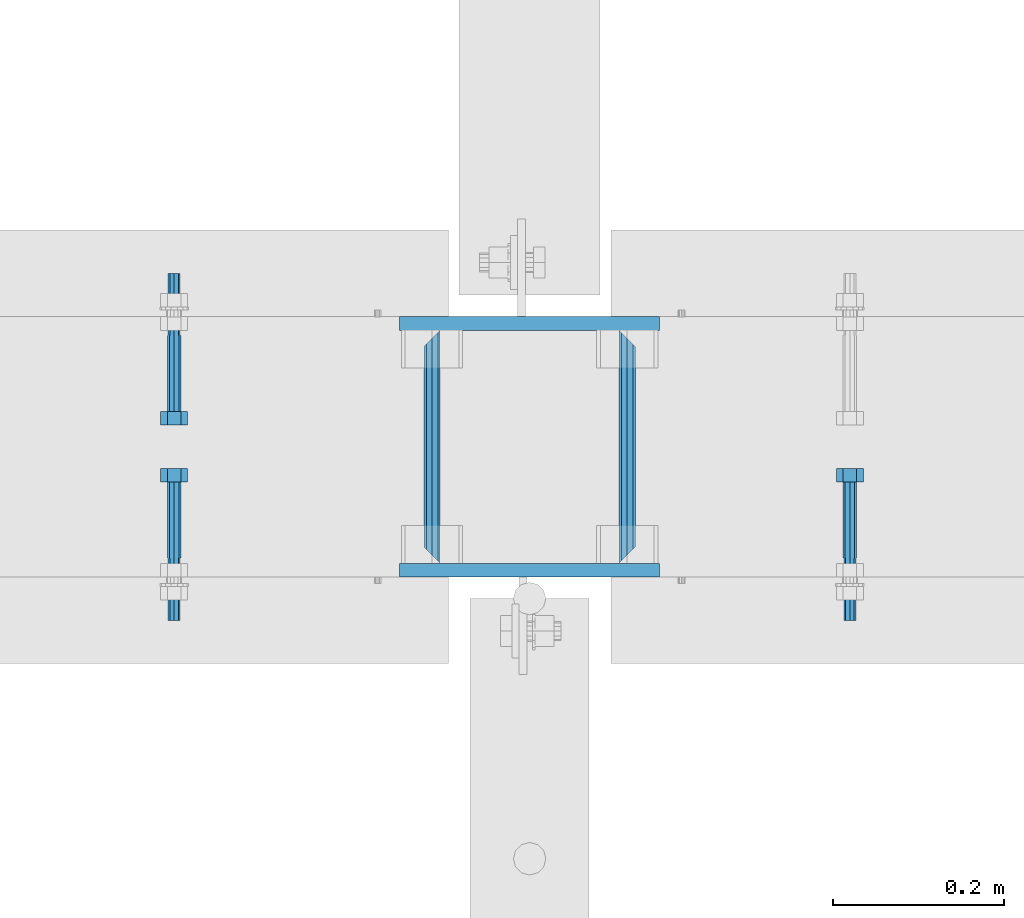
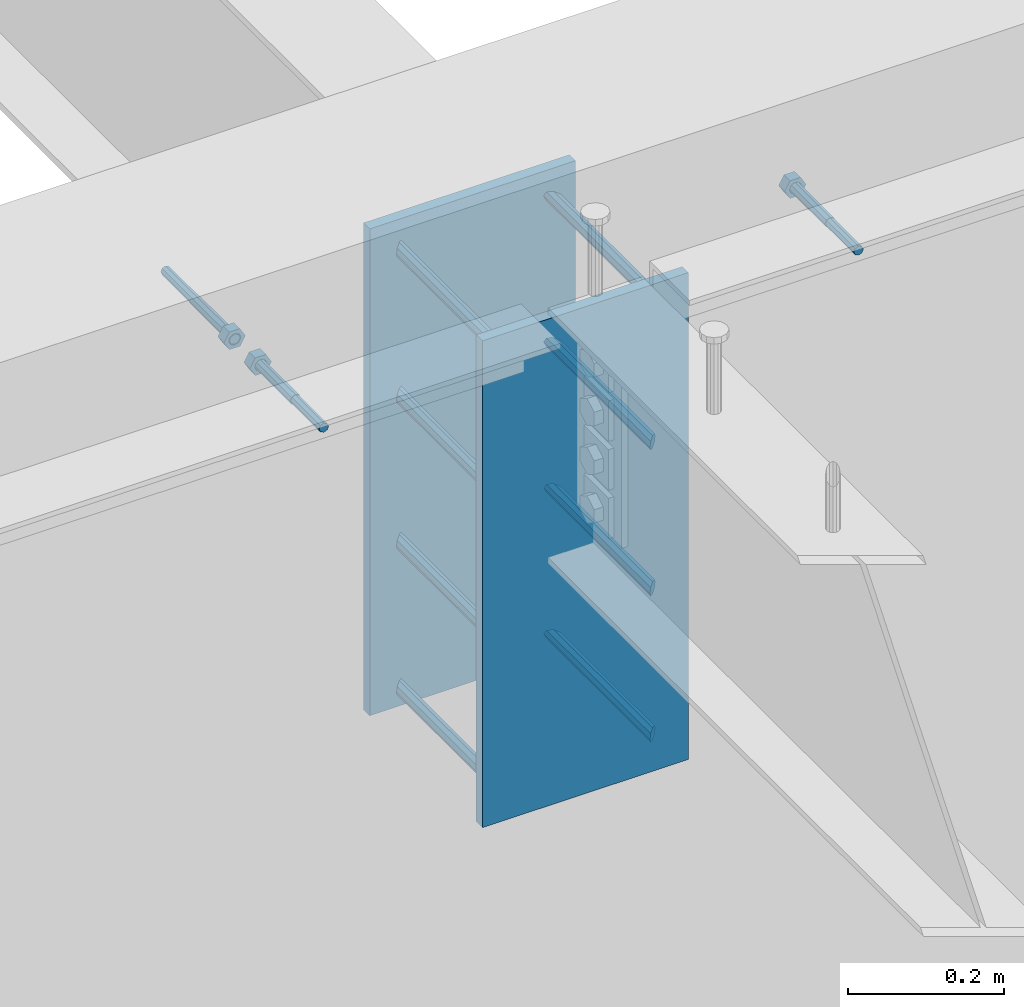
# One storey, part 428 of 975: 13 beams.
"""IFC2X3 building model written with IfcOpenShell, lengths in millimetres."""

from ifc_helpers import new_model, si_unit, frame, origin_with_axes, place, context, subcontext, project, spatial, faceted_brep, material, type_object, element, save


model = new_model("IFC2X3")

# Units and contexts
model_context = context("Model", 3, precision=1e-05, world=origin_with_axes())
body_context = subcontext(model_context, "Body", "Model", "MODEL_VIEW")
ifc_project = project(units=[si_unit("LENGTHUNIT", "METRE", prefix="MILLI"), si_unit("AREAUNIT", "SQUARE_METRE"), si_unit("VOLUMEUNIT", "CUBIC_METRE"), si_unit("MASSUNIT", "GRAM", prefix="KILO"), si_unit("TIMEUNIT", "SECOND"), si_unit("PLANEANGLEUNIT", "RADIAN"), si_unit("SOLIDANGLEUNIT", "STERADIAN"), si_unit("THERMODYNAMICTEMPERATUREUNIT", "DEGREE_CELSIUS"), si_unit("LUMINOUSINTENSITYUNIT", "LUMEN")], contexts=[model_context])

# Site, building, storey
site_placement = place(None, origin_with_axes())
site = spatial("IfcSite", under=ifc_project, at=site_placement, CompositionType="ELEMENT")
building_placement = place(site_placement, origin_with_axes())
building = spatial("IfcBuilding", under=site, at=building_placement, Name="Undefined", CompositionType="ELEMENT")
storey_placement = place(building_placement, origin_with_axes())
storey = spatial("IfcBuildingStorey", under=building, at=storey_placement, Name="Undefined", CompositionType="ELEMENT", Elevation=0.0)

# Beams
ifc_material_1 = material(Name="STEEL/F1554-36")
beam_type_1 = type_object("IfcBeamType", PredefinedType="NOTDEFINED")
beam_1_placement = place(storey_placement, frame((3874.0292047886, 20726.3999996637, 3886.2), z_axis=(0.0, 0.0, 1.0), x_axis=(0.0, -1.0, 0.0)))
element("IfcBeam", 1, at=beam_1_placement, inside=storey, type_object=beam_type_1, material=ifc_material_1, Name="HEADED_ANCHOR_BOLT", context=body_context, shape_type="Brep", body=[
    faceted_brep([(88.9000000184824, 7.94000001861696, -13.7499999799138), (88.8999999527368, 15.8800000758411, 2.00943759409711e-08), (104.774999952569, 15.8800001213949, 6.97191353538074e-08), (104.775000018315, 7.94000006417082, -13.7499999302891), (88.900000064019, -7.94000009583215, -13.7499999799147), (104.775000063852, -7.9400000502792, -13.74999993029), (88.9000000438027, -15.880000153059, 2.00925569515675e-08), (104.775000043643, -15.8800001075042, 6.9716406869702e-08), (88.8999999780608, -7.94000009583488, 13.7500000200998), (104.774999977893, -7.94000005028101, 13.7500000697237), (88.8999999325279, 7.94000001861514, 13.7500000201007), (104.774999932361, 7.940000064169, 13.7500000697246), (88.9000000119959, 3.78780480527439, -7.86545778426807), (88.8999999957159, 6.82538844544797, -5.4430656647246), (88.8999999799416, 8.51112018845743, -1.94260763148395), (88.8999999677944, 8.51112018845652, 1.94260767167179), (88.8999999616899, 6.82538844544615, 5.44306570491244), (88.8999999628249, 3.78780480527257, 7.86545782445592), (88.8999999709849, -3.86089595849626e-08, 8.72999956233434), (88.8999999845473, -3.7878048824914, 7.8654578244541), (88.9000000008309, -6.82538852266407, 5.44306570491153), (88.9000000166052, -8.51112026567444, 1.94260767166998), (88.9000000287488, -8.51112026567353, -1.94260763148577), (88.9000000348606, -6.82538852266407, -5.44306566472642), (88.9000000337182, -3.78780488248958, -7.86545778426898), (88.9000000255583, -3.86080500902608e-08, -8.72999952214832), (104.775000025395, 6.94581103743985e-09, -8.72999947252447), (104.775000011829, 3.78780485082825, -7.86545773464422), (104.774999995549, 6.82538849100092, -5.44306561510075), (104.774999979774, 8.51112023401038, -1.9426075818601), (104.774999967627, 8.51112023401038, 1.94260772129564), (104.774999961523, 6.82538849100092, 5.44306575453629), (104.774999962658, 3.78780485082643, 7.86545787407977), (104.774999970818, 6.94399204803631e-09, 8.7299996119591), (104.77499998438, -3.78780483693754, 7.86545787407886), (104.775000000664, -6.82538847711112, 5.44306575453538), (104.775000016438, -8.51112022012057, 1.94260772129473), (104.775000028581, -8.51112022012057, -1.94260758186101), (104.775000034693, -6.82538847711021, -5.44306561510166), (104.775000033551, -3.78780483693663, -7.86545773464422), (-2.99107341561466e-07, -5.61266007567065, 5.61266007566792), (-4.22995071858168e-07, -7.93750000000728, 0.0), (104.774999998088, -7.93749999999, -4.45652403868735e-11), (104.774999998088, -5.61266007565791, 5.61266007562426), (-1.09139364212751e-11, 1.81898940354586e-12, 7.9375), (104.774999998095, 1.18234311230481e-11, 7.93749999995816), (2.99089151667431e-07, 5.61266007567428, 5.61266007566792), (104.774999998102, 5.61266007568065, 5.61266007562517), (4.22980519942939e-07, 7.93750000001091, 0.0), (104.77499999811, 7.93750000001364, -4.36557456851006e-11), (2.99089151667431e-07, 5.61266007567428, -5.61266007566792), (104.774999998102, 5.61266007568156, -5.61266007571339), (-1.09139364212751e-11, 1.81898940354586e-12, -7.9375), (104.774999998099, 1.2732925824821e-11, -7.93750000004547), (-73.0249999592124, 5.05157065939329, -5.0515715445581), (-73.0249999269472, -1.85405951924622e-07, -7.14400069976364), (-73.0249999328516, -5.0515710302052, -5.05157154455992), (-73.0249999734697, -7.14400018541073, -6.9975976657588e-07), (-73.0250000250016, -5.05157103020611, 5.05157014504039), (-73.0250000572705, -1.85406861419324e-07, 7.1439993002441), (-73.0250000513661, 5.05157065939238, 5.05157014503948), (-73.025000010748, 7.14399981459792, -6.99758857081179e-07), (0.00625003290042514, 5.05157085007795, -5.05157087849238), (0.00625006516929716, 5.27870724909008e-09, -7.1440000336961), (0.00625005926485755, -5.05157083952145, -5.05157087849329), (0.00625001864682417, -7.14399999472516, -3.36940502165817e-08), (0.00624996711121639, -5.05157083952145, 5.05157081110519), (0.00624993484598235, 5.2777977543883e-09, 7.14399996631164), (0.00624994074678398, 5.05157085007704, 5.05157081110701), (0.00624998136845534, 7.14400000528167, -3.36922312271781e-08), (-2.99107341561466e-07, -5.61266007567065, -5.61266007566792), (104.774999998092, -5.612660075657, -5.6126600757143)], [[[0, 1, 2, 3]], [[4, 0, 3, 5]], [[6, 4, 5, 7]], [[8, 6, 7, 9]], [[10, 8, 9, 11]], [[0, 4, 6, 8, 10, 1], [12, 13, 14, 15, 16, 17, 18, 19, 20, 21, 22, 23, 24, 25]], [[12, 25, 26, 27]], [[13, 12, 27, 28]], [[14, 13, 28, 29]], [[15, 14, 29, 30]], [[16, 15, 30, 31]], [[17, 16, 31, 32]], [[18, 17, 32, 33]], [[19, 18, 33, 34]], [[20, 19, 34, 35]], [[21, 20, 35, 36]], [[22, 21, 36, 37]], [[23, 22, 37, 38]], [[24, 23, 38, 39]], [[25, 24, 39, 26]], [[9, 7, 5, 3, 2, 11], [38, 37, 36, 35, 34, 33, 32, 31, 30, 29, 28, 27, 26, 39]], [[1, 10, 11, 2]], [[40, 41, 42, 43]], [[44, 40, 43, 45]], [[46, 44, 45, 47]], [[48, 46, 47, 49]], [[50, 48, 49, 51]], [[52, 50, 51, 53]], [[54, 55, 56, 57, 58, 59, 60, 61]], [[55, 54, 62, 63]], [[56, 55, 63, 64]], [[57, 56, 64, 65]], [[58, 57, 65, 66]], [[59, 58, 66, 67]], [[60, 59, 67, 68]], [[61, 60, 68, 69]], [[54, 61, 69, 62]], [[40, 44, 46, 48, 50, 52, 70, 41], [68, 67, 66, 65, 64, 63, 62, 69]], [[41, 70, 71, 42]], [[53, 51, 49, 47, 45, 43, 42, 71]], [[70, 52, 53, 71]]]),
])
beam_2_placement = place(storey_placement, frame((4665.66261822082, 20466.05, 3886.2), z_axis=(0.0, 0.0, 1.0), x_axis=(0.0, 1.0, 0.0)))
element("IfcBeam", 2, at=beam_2_placement, inside=storey, type_object=beam_type_1, material=ifc_material_1, Name="HEADED_ANCHOR_BOLT", context=body_context, shape_type="Brep", body=[
    faceted_brep([(88.9000000184824, 7.94000001861696, -13.7499999799138), (88.8999999527368, 15.8800000758411, 2.00943759409711e-08), (104.774999952569, 15.8800001213949, 6.97191353538074e-08), (104.775000018315, 7.94000006417082, -13.7499999302891), (88.900000064019, -7.94000009583215, -13.7499999799147), (104.775000063852, -7.9400000502792, -13.74999993029), (88.9000000438027, -15.880000153059, 2.00925569515675e-08), (104.775000043643, -15.8800001075042, 6.9716406869702e-08), (88.8999999780608, -7.94000009583488, 13.7500000200998), (104.774999977893, -7.94000005028101, 13.7500000697237), (88.8999999325279, 7.94000001861514, 13.7500000201007), (104.774999932361, 7.940000064169, 13.7500000697246), (88.9000000119959, 3.78780480527439, -7.86545778426807), (88.8999999957159, 6.82538844544797, -5.4430656647246), (88.8999999799416, 8.51112018845743, -1.94260763148395), (88.8999999677944, 8.51112018845652, 1.94260767167179), (88.8999999616899, 6.82538844544615, 5.44306570491244), (88.8999999628249, 3.78780480527257, 7.86545782445592), (88.8999999709849, -3.86089595849626e-08, 8.72999956233434), (88.8999999845473, -3.7878048824914, 7.8654578244541), (88.9000000008309, -6.82538852266407, 5.44306570491153), (88.9000000166052, -8.51112026567444, 1.94260767166998), (88.9000000287488, -8.51112026567353, -1.94260763148577), (88.9000000348606, -6.82538852266407, -5.44306566472642), (88.9000000337182, -3.78780488248958, -7.86545778426898), (88.9000000255583, -3.86080500902608e-08, -8.72999952214832), (104.775000025395, 6.94581103743985e-09, -8.72999947252447), (104.775000011829, 3.78780485082825, -7.86545773464422), (104.774999995549, 6.82538849100092, -5.44306561510075), (104.774999979774, 8.51112023401038, -1.9426075818601), (104.774999967627, 8.51112023401038, 1.94260772129564), (104.774999961523, 6.82538849100092, 5.44306575453629), (104.774999962658, 3.78780485082643, 7.86545787407977), (104.774999970818, 6.94399204803631e-09, 8.7299996119591), (104.77499998438, -3.78780483693754, 7.86545787407886), (104.775000000664, -6.82538847711112, 5.44306575453538), (104.775000016438, -8.51112022012057, 1.94260772129473), (104.775000028581, -8.51112022012057, -1.94260758186101), (104.775000034693, -6.82538847711021, -5.44306561510166), (104.775000033551, -3.78780483693663, -7.86545773464422), (-2.99107341561466e-07, -5.61266007567065, 5.61266007566792), (-4.22995071858168e-07, -7.93750000000728, 0.0), (104.774999998088, -7.93749999999, -4.45652403868735e-11), (104.774999998088, -5.61266007565791, 5.61266007562426), (-1.09139364212751e-11, 1.81898940354586e-12, 7.9375), (104.774999998095, 1.18234311230481e-11, 7.93749999995816), (2.99089151667431e-07, 5.61266007567428, 5.61266007566792), (104.774999998102, 5.61266007568065, 5.61266007562517), (4.22980519942939e-07, 7.93750000001091, 0.0), (104.77499999811, 7.93750000001364, -4.36557456851006e-11), (2.99089151667431e-07, 5.61266007567428, -5.61266007566792), (104.774999998102, 5.61266007568156, -5.61266007571339), (-1.09139364212751e-11, 1.81898940354586e-12, -7.9375), (104.774999998099, 1.2732925824821e-11, -7.93750000004547), (-73.0249999592124, 5.05157065939329, -5.0515715445581), (-73.0249999269472, -1.85405951924622e-07, -7.14400069976364), (-73.0249999328516, -5.0515710302052, -5.05157154455992), (-73.0249999734697, -7.14400018541073, -6.9975976657588e-07), (-73.0250000250016, -5.05157103020611, 5.05157014504039), (-73.0250000572705, -1.85406861419324e-07, 7.1439993002441), (-73.0250000513661, 5.05157065939238, 5.05157014503948), (-73.025000010748, 7.14399981459792, -6.99758857081179e-07), (0.00625003290042514, 5.05157085007795, -5.05157087849238), (0.00625006516929716, 5.27870724909008e-09, -7.1440000336961), (0.00625005926485755, -5.05157083952145, -5.05157087849329), (0.00625001864682417, -7.14399999472516, -3.36940502165817e-08), (0.00624996711121639, -5.05157083952145, 5.05157081110519), (0.00624993484598235, 5.2777977543883e-09, 7.14399996631164), (0.00624994074678398, 5.05157085007704, 5.05157081110701), (0.00624998136845534, 7.14400000528167, -3.36922312271781e-08), (-2.99107341561466e-07, -5.61266007567065, -5.61266007566792), (104.774999998092, -5.612660075657, -5.6126600757143)], [[[0, 1, 2, 3]], [[4, 0, 3, 5]], [[6, 4, 5, 7]], [[8, 6, 7, 9]], [[10, 8, 9, 11]], [[0, 4, 6, 8, 10, 1], [12, 13, 14, 15, 16, 17, 18, 19, 20, 21, 22, 23, 24, 25]], [[12, 25, 26, 27]], [[13, 12, 27, 28]], [[14, 13, 28, 29]], [[15, 14, 29, 30]], [[16, 15, 30, 31]], [[17, 16, 31, 32]], [[18, 17, 32, 33]], [[19, 18, 33, 34]], [[20, 19, 34, 35]], [[21, 20, 35, 36]], [[22, 21, 36, 37]], [[23, 22, 37, 38]], [[24, 23, 38, 39]], [[25, 24, 39, 26]], [[9, 7, 5, 3, 2, 11], [38, 37, 36, 35, 34, 33, 32, 31, 30, 29, 28, 27, 26, 39]], [[1, 10, 11, 2]], [[40, 41, 42, 43]], [[44, 40, 43, 45]], [[46, 44, 45, 47]], [[48, 46, 47, 49]], [[50, 48, 49, 51]], [[52, 50, 51, 53]], [[54, 55, 56, 57, 58, 59, 60, 61]], [[55, 54, 62, 63]], [[56, 55, 63, 64]], [[57, 56, 64, 65]], [[58, 57, 65, 66]], [[59, 58, 66, 67]], [[60, 59, 67, 68]], [[61, 60, 68, 69]], [[54, 61, 69, 62]], [[40, 44, 46, 48, 50, 52, 70, 41], [68, 67, 66, 65, 64, 63, 62, 69]], [[41, 70, 71, 42]], [[53, 51, 49, 47, 45, 43, 42, 71]], [[70, 52, 53, 71]]]),
])
beam_3_placement = place(storey_placement, frame((3874.0292047886, 20466.05, 3886.2), z_axis=(0.0, 0.0, -1.0), x_axis=(0.0, 1.0, 0.0)))
element("IfcBeam", 3, at=beam_3_placement, inside=storey, type_object=beam_type_1, material=ifc_material_1, Name="HEADED_ANCHOR_BOLT", context=body_context, shape_type="Brep", body=[
    faceted_brep([(88.9000000184824, 7.94000001861696, -13.7499999799138), (88.8999999527368, 15.8800000758411, 2.00943759409711e-08), (104.774999952569, 15.8800001213949, 6.97191353538074e-08), (104.775000018315, 7.94000006417082, -13.7499999302891), (88.900000064019, -7.94000009583215, -13.7499999799147), (104.775000063852, -7.9400000502792, -13.74999993029), (88.9000000438027, -15.880000153059, 2.00925569515675e-08), (104.775000043643, -15.8800001075042, 6.9716406869702e-08), (88.8999999780608, -7.94000009583488, 13.7500000200998), (104.774999977893, -7.94000005028101, 13.7500000697237), (88.8999999325279, 7.94000001861514, 13.7500000201007), (104.774999932361, 7.940000064169, 13.7500000697246), (88.9000000119959, 3.78780480527439, -7.86545778426807), (88.8999999957159, 6.82538844544797, -5.4430656647246), (88.8999999799416, 8.51112018845743, -1.94260763148395), (88.8999999677944, 8.51112018845652, 1.94260767167179), (88.8999999616899, 6.82538844544615, 5.44306570491244), (88.8999999628249, 3.78780480527257, 7.86545782445592), (88.8999999709849, -3.86089595849626e-08, 8.72999956233434), (88.8999999845473, -3.7878048824914, 7.8654578244541), (88.9000000008309, -6.82538852266407, 5.44306570491153), (88.9000000166052, -8.51112026567444, 1.94260767166998), (88.9000000287488, -8.51112026567353, -1.94260763148577), (88.9000000348606, -6.82538852266407, -5.44306566472642), (88.9000000337182, -3.78780488248958, -7.86545778426898), (88.9000000255583, -3.86080500902608e-08, -8.72999952214832), (104.775000025395, 6.94581103743985e-09, -8.72999947252447), (104.775000011829, 3.78780485082825, -7.86545773464422), (104.774999995549, 6.82538849100092, -5.44306561510075), (104.774999979774, 8.51112023401038, -1.9426075818601), (104.774999967627, 8.51112023401038, 1.94260772129564), (104.774999961523, 6.82538849100092, 5.44306575453629), (104.774999962658, 3.78780485082643, 7.86545787407977), (104.774999970818, 6.94399204803631e-09, 8.7299996119591), (104.77499998438, -3.78780483693754, 7.86545787407886), (104.775000000664, -6.82538847711112, 5.44306575453538), (104.775000016438, -8.51112022012057, 1.94260772129473), (104.775000028581, -8.51112022012057, -1.94260758186101), (104.775000034693, -6.82538847711021, -5.44306561510166), (104.775000033551, -3.78780483693663, -7.86545773464422), (-2.99107341561466e-07, -5.61266007567065, 5.61266007566792), (-4.22995071858168e-07, -7.93750000000728, 0.0), (104.774999998088, -7.93749999999, -4.45652403868735e-11), (104.774999998088, -5.61266007565791, 5.61266007562426), (-1.09139364212751e-11, 1.81898940354586e-12, 7.9375), (104.774999998095, 1.18234311230481e-11, 7.93749999995816), (2.99089151667431e-07, 5.61266007567428, 5.61266007566792), (104.774999998102, 5.61266007568065, 5.61266007562517), (4.22980519942939e-07, 7.93750000001091, 0.0), (104.77499999811, 7.93750000001364, -4.36557456851006e-11), (2.99089151667431e-07, 5.61266007567428, -5.61266007566792), (104.774999998102, 5.61266007568156, -5.61266007571339), (-1.09139364212751e-11, 1.81898940354586e-12, -7.9375), (104.774999998099, 1.2732925824821e-11, -7.93750000004547), (-73.0249999592124, 5.05157065939329, -5.0515715445581), (-73.0249999269472, -1.85405951924622e-07, -7.14400069976364), (-73.0249999328516, -5.0515710302052, -5.05157154455992), (-73.0249999734697, -7.14400018541073, -6.9975976657588e-07), (-73.0250000250016, -5.05157103020611, 5.05157014504039), (-73.0250000572705, -1.85406861419324e-07, 7.1439993002441), (-73.0250000513661, 5.05157065939238, 5.05157014503948), (-73.025000010748, 7.14399981459792, -6.99758857081179e-07), (0.00625003290042514, 5.05157085007795, -5.05157087849238), (0.00625006516929716, 5.27870724909008e-09, -7.1440000336961), (0.00625005926485755, -5.05157083952145, -5.05157087849329), (0.00625001864682417, -7.14399999472516, -3.36940502165817e-08), (0.00624996711121639, -5.05157083952145, 5.05157081110519), (0.00624993484598235, 5.2777977543883e-09, 7.14399996631164), (0.00624994074678398, 5.05157085007704, 5.05157081110701), (0.00624998136845534, 7.14400000528167, -3.36922312271781e-08), (-2.99107341561466e-07, -5.61266007567065, -5.61266007566792), (104.774999998092, -5.612660075657, -5.6126600757143)], [[[0, 1, 2, 3]], [[4, 0, 3, 5]], [[6, 4, 5, 7]], [[8, 6, 7, 9]], [[10, 8, 9, 11]], [[0, 4, 6, 8, 10, 1], [12, 13, 14, 15, 16, 17, 18, 19, 20, 21, 22, 23, 24, 25]], [[12, 25, 26, 27]], [[13, 12, 27, 28]], [[14, 13, 28, 29]], [[15, 14, 29, 30]], [[16, 15, 30, 31]], [[17, 16, 31, 32]], [[18, 17, 32, 33]], [[19, 18, 33, 34]], [[20, 19, 34, 35]], [[21, 20, 35, 36]], [[22, 21, 36, 37]], [[23, 22, 37, 38]], [[24, 23, 38, 39]], [[25, 24, 39, 26]], [[9, 7, 5, 3, 2, 11], [38, 37, 36, 35, 34, 33, 32, 31, 30, 29, 28, 27, 26, 39]], [[1, 10, 11, 2]], [[40, 41, 42, 43]], [[44, 40, 43, 45]], [[46, 44, 45, 47]], [[48, 46, 47, 49]], [[50, 48, 49, 51]], [[52, 50, 51, 53]], [[54, 55, 56, 57, 58, 59, 60, 61]], [[55, 54, 62, 63]], [[56, 55, 63, 64]], [[57, 56, 64, 65]], [[58, 57, 65, 66]], [[59, 58, 66, 67]], [[60, 59, 67, 68]], [[61, 60, 68, 69]], [[54, 61, 69, 62]], [[40, 44, 46, 48, 50, 52, 70, 41], [68, 67, 66, 65, 64, 63, 62, 69]], [[41, 70, 71, 42]], [[53, 51, 49, 47, 45, 43, 42, 71]], [[70, 52, 53, 71]]]),
])
ifc_material_2 = material(Name="STEEL/A36")
beam_type_2 = type_object("IfcBeamType", PredefinedType="NOTDEFINED")
beam_4_placement = place(storey_placement, frame((4404.78345841014, 20459.7, 3403.6), z_axis=(0.0, 0.0, 1.0), x_axis=(0.0, 1.0, 0.0)))
element("IfcBeam", 4, at=beam_4_placement, inside=storey, type_object=beam_type_2, material=ifc_material_2, Name="ROD", context=body_context, shape_type="Brep", body=[
    faceted_brep([(19.0499992370605, -9.52499923706273, 0.0), (16.2601920907982, -6.73519209080223, 6.73519209080177), (9.52499999999782, 0.0, 9.52500000000009), (2.78980790919741, 6.73519209080223, 6.73519209080177), (0.0, 9.52499999999964, 0.0), (2.78980790919741, 6.73519209080223, -6.73519209080177), (9.52499999999782, 0.0, -9.52500000000009), (16.2601920907982, -6.73519209080223, -6.73519209080177), (273.050000000003, 9.52499999999782, 0.0), (270.260192090806, 6.73519209080223, 6.73519209080177), (263.525000000005, 0.0, 9.52500000000009), (256.789807909205, -6.73519209080223, 6.73519209080177), (254.000000762942, -9.52499999999964, 0.0), (256.789807909205, -6.73519209080223, -6.73519209080177), (263.525000000005, 0.0, -9.52500000000009), (270.260192090806, 6.73519209080223, -6.73519209080177)], [[[0, 1, 2, 3, 4, 5, 6, 7]], [[8, 9, 10, 11, 12, 13, 14, 15]], [[13, 12, 0, 7]], [[14, 13, 7, 6]], [[15, 14, 6, 5]], [[8, 15, 5, 4]], [[9, 8, 4, 3]], [[10, 9, 3, 2]], [[11, 10, 2, 1]], [[12, 11, 1, 0]]]),
])
beam_5_placement = place(storey_placement, frame((4176.18345841015, 20459.7, 3403.6), z_axis=(0.0, 0.0, 1.0), x_axis=(0.0, 1.0, 0.0)))
element("IfcBeam", 5, at=beam_5_placement, inside=storey, type_object=beam_type_2, material=ifc_material_2, Name="ROD", context=body_context, shape_type="Brep", body=[
    faceted_brep([(19.0499992370605, 9.52499923706091, 0.0), (16.2601920908019, 6.73519209080223, -6.73519209080177), (9.52499999999782, 0.0, -9.52500000000009), (2.78980790919741, -6.73519209080223, -6.73519209080177), (0.0, -9.52499999999964, 0.0), (2.78980790919741, -6.73519209080223, 6.73519209080177), (9.52499999999782, 0.0, 9.52500000000009), (16.2601920908019, 6.73519209080223, 6.73519209080177), (273.050000000003, -9.52499999999964, 0.0), (270.260192090806, -6.73519209080223, -6.73519209080177), (263.525000000005, 0.0, -9.52500000000009), (256.789807909201, 6.73519209080223, -6.73519209080177), (254.000000762942, 9.52499999999964, 0.0), (256.789807909201, 6.73519209080223, 6.73519209080177), (263.525000000005, 0.0, 9.52500000000009), (270.260192090806, -6.73519209080223, 6.73519209080177)], [[[0, 1, 2, 3, 4, 5, 6, 7]], [[8, 9, 10, 11, 12, 13, 14, 15]], [[13, 12, 0, 7]], [[14, 13, 7, 6]], [[15, 14, 6, 5]], [[8, 15, 5, 4]], [[9, 8, 4, 3]], [[10, 9, 3, 2]], [[11, 10, 2, 1]], [[12, 11, 1, 0]]]),
])
beam_6_placement = place(storey_placement, frame((4404.78345841014, 20459.7, 3632.2), z_axis=(0.0, 0.0, 1.0), x_axis=(0.0, 1.0, 0.0)))
element("IfcBeam", 6, at=beam_6_placement, inside=storey, type_object=beam_type_2, material=ifc_material_2, Name="ROD", context=body_context, shape_type="Brep", body=[
    faceted_brep([(19.0499992370605, -9.52499923706273, 0.0), (16.2601920907982, -6.73519209080223, 6.73519209080177), (9.52499999999782, 0.0, 9.52500000000009), (2.78980790919741, 6.73519209080223, 6.73519209080177), (0.0, 9.52499999999964, 0.0), (2.78980790919741, 6.73519209080223, -6.73519209080177), (9.52499999999782, 0.0, -9.52500000000009), (16.2601920907982, -6.73519209080223, -6.73519209080177), (273.050000000003, 9.52499999999782, 0.0), (270.260192090806, 6.73519209080223, 6.73519209080177), (263.525000000005, 0.0, 9.52500000000009), (256.789807909205, -6.73519209080223, 6.73519209080177), (254.000000762942, -9.52499999999964, 0.0), (256.789807909205, -6.73519209080223, -6.73519209080177), (263.525000000005, 0.0, -9.52500000000009), (270.260192090806, 6.73519209080223, -6.73519209080177)], [[[0, 1, 2, 3, 4, 5, 6, 7]], [[8, 9, 10, 11, 12, 13, 14, 15]], [[13, 12, 0, 7]], [[14, 13, 7, 6]], [[15, 14, 6, 5]], [[8, 15, 5, 4]], [[9, 8, 4, 3]], [[10, 9, 3, 2]], [[11, 10, 2, 1]], [[12, 11, 1, 0]]]),
])
beam_7_placement = place(storey_placement, frame((4176.18345841015, 20459.7, 3632.2), z_axis=(0.0, 0.0, 1.0), x_axis=(0.0, 1.0, 0.0)))
element("IfcBeam", 7, at=beam_7_placement, inside=storey, type_object=beam_type_2, material=ifc_material_2, Name="ROD", context=body_context, shape_type="Brep", body=[
    faceted_brep([(19.0499992370605, 9.52499923706091, 0.0), (16.2601920908019, 6.73519209080223, -6.73519209080177), (9.52499999999782, 0.0, -9.52500000000009), (2.78980790919741, -6.73519209080223, -6.73519209080177), (0.0, -9.52499999999964, 0.0), (2.78980790919741, -6.73519209080223, 6.73519209080177), (9.52499999999782, 0.0, 9.52500000000009), (16.2601920908019, 6.73519209080223, 6.73519209080177), (273.050000000003, -9.52499999999964, 0.0), (270.260192090806, -6.73519209080223, -6.73519209080177), (263.525000000005, 0.0, -9.52500000000009), (256.789807909201, 6.73519209080223, -6.73519209080177), (254.000000762942, 9.52499999999964, 0.0), (256.789807909201, 6.73519209080223, 6.73519209080177), (263.525000000005, 0.0, 9.52500000000009), (270.260192090806, -6.73519209080223, 6.73519209080177)], [[[0, 1, 2, 3, 4, 5, 6, 7]], [[8, 9, 10, 11, 12, 13, 14, 15]], [[13, 12, 0, 7]], [[14, 13, 7, 6]], [[15, 14, 6, 5]], [[8, 15, 5, 4]], [[9, 8, 4, 3]], [[10, 9, 3, 2]], [[11, 10, 2, 1]], [[12, 11, 1, 0]]]),
])
beam_8_placement = place(storey_placement, frame((4404.78345841014, 20459.7, 3175.0), z_axis=(0.0, 0.0, 1.0), x_axis=(0.0, 1.0, 0.0)))
element("IfcBeam", 8, at=beam_8_placement, inside=storey, type_object=beam_type_2, material=ifc_material_2, Name="ROD", context=body_context, shape_type="Brep", body=[
    faceted_brep([(19.0499992370605, -9.52499923706273, 0.0), (16.2601920907982, -6.73519209080223, 6.73519209080177), (9.52499999999782, 0.0, 9.52500000000009), (2.78980790919741, 6.73519209080223, 6.73519209080177), (0.0, 9.52499999999964, 0.0), (2.78980790919741, 6.73519209080223, -6.73519209080177), (9.52499999999782, 0.0, -9.52500000000009), (16.2601920907982, -6.73519209080223, -6.73519209080177), (273.050000000003, 9.52499999999782, 0.0), (270.260192090806, 6.73519209080223, 6.73519209080177), (263.525000000005, 0.0, 9.52500000000009), (256.789807909205, -6.73519209080223, 6.73519209080177), (254.000000762942, -9.52499999999964, 0.0), (256.789807909205, -6.73519209080223, -6.73519209080177), (263.525000000005, 0.0, -9.52500000000009), (270.260192090806, 6.73519209080223, -6.73519209080177)], [[[0, 1, 2, 3, 4, 5, 6, 7]], [[8, 9, 10, 11, 12, 13, 14, 15]], [[13, 12, 0, 7]], [[14, 13, 7, 6]], [[15, 14, 6, 5]], [[8, 15, 5, 4]], [[9, 8, 4, 3]], [[10, 9, 3, 2]], [[11, 10, 2, 1]], [[12, 11, 1, 0]]]),
])
beam_9_placement = place(storey_placement, frame((4176.18345841015, 20459.7, 3175.0), z_axis=(0.0, 0.0, 1.0), x_axis=(0.0, 1.0, 0.0)))
element("IfcBeam", 9, at=beam_9_placement, inside=storey, type_object=beam_type_2, material=ifc_material_2, Name="ROD", context=body_context, shape_type="Brep", body=[
    faceted_brep([(19.0499992370605, 9.52499923706091, 0.0), (16.2601920908019, 6.73519209080223, -6.73519209080177), (9.52499999999782, 0.0, -9.52500000000009), (2.78980790919741, -6.73519209080223, -6.73519209080177), (0.0, -9.52499999999964, 0.0), (2.78980790919741, -6.73519209080223, 6.73519209080177), (9.52499999999782, 0.0, 9.52500000000009), (16.2601920908019, 6.73519209080223, 6.73519209080177), (273.050000000003, -9.52499999999964, 0.0), (270.260192090806, -6.73519209080223, -6.73519209080177), (263.525000000005, 0.0, -9.52500000000009), (256.789807909201, 6.73519209080223, -6.73519209080177), (254.000000762942, 9.52499999999964, 0.0), (256.789807909201, 6.73519209080223, 6.73519209080177), (263.525000000005, 0.0, 9.52500000000009), (270.260192090806, -6.73519209080223, 6.73519209080177)], [[[0, 1, 2, 3, 4, 5, 6, 7]], [[8, 9, 10, 11, 12, 13, 14, 15]], [[13, 12, 0, 7]], [[14, 13, 7, 6]], [[15, 14, 6, 5]], [[8, 15, 5, 4]], [[9, 8, 4, 3]], [[10, 9, 3, 2]], [[11, 10, 2, 1]], [[12, 11, 1, 0]]]),
])
beam_10_placement = place(storey_placement, frame((4404.78345841014, 20459.7, 3860.8), z_axis=(0.0, 0.0, 1.0), x_axis=(0.0, 1.0, 0.0)))
element("IfcBeam", 10, at=beam_10_placement, inside=storey, type_object=beam_type_2, material=ifc_material_2, Name="ROD", context=body_context, shape_type="Brep", body=[
    faceted_brep([(19.0499992370605, -9.52499923706273, 0.0), (16.2601920907982, -6.73519209080223, 6.73519209080177), (9.52499999999782, 0.0, 9.52500000000009), (2.78980790919741, 6.73519209080223, 6.73519209080177), (0.0, 9.52499999999964, 0.0), (2.78980790919741, 6.73519209080223, -6.73519209080177), (9.52499999999782, 0.0, -9.52500000000009), (16.2601920907982, -6.73519209080223, -6.73519209080177), (273.050000000003, 9.52499999999782, 0.0), (270.260192090806, 6.73519209080223, 6.73519209080177), (263.525000000005, 0.0, 9.52500000000009), (256.789807909205, -6.73519209080223, 6.73519209080177), (254.000000762942, -9.52499999999964, 0.0), (256.789807909205, -6.73519209080223, -6.73519209080177), (263.525000000005, 0.0, -9.52500000000009), (270.260192090806, 6.73519209080223, -6.73519209080177)], [[[0, 1, 2, 3, 4, 5, 6, 7]], [[8, 9, 10, 11, 12, 13, 14, 15]], [[13, 12, 0, 7]], [[14, 13, 7, 6]], [[15, 14, 6, 5]], [[8, 15, 5, 4]], [[9, 8, 4, 3]], [[10, 9, 3, 2]], [[11, 10, 2, 1]], [[12, 11, 1, 0]]]),
])
beam_11_placement = place(storey_placement, frame((4176.18345841015, 20459.7, 3860.8), z_axis=(0.0, 0.0, 1.0), x_axis=(0.0, 1.0, 0.0)))
element("IfcBeam", 11, at=beam_11_placement, inside=storey, type_object=beam_type_2, material=ifc_material_2, Name="ROD", context=body_context, shape_type="Brep", body=[
    faceted_brep([(19.0499992370605, 9.52499923706091, 0.0), (16.2601920908019, 6.73519209080223, -6.73519209080177), (9.52499999999782, 0.0, -9.52500000000009), (2.78980790919741, -6.73519209080223, -6.73519209080177), (0.0, -9.52499999999964, 0.0), (2.78980790919741, -6.73519209080223, 6.73519209080177), (9.52499999999782, 0.0, 9.52500000000009), (16.2601920908019, 6.73519209080223, 6.73519209080177), (273.050000000003, -9.52499999999964, 0.0), (270.260192090806, -6.73519209080223, -6.73519209080177), (263.525000000005, 0.0, -9.52500000000009), (256.789807909201, 6.73519209080223, -6.73519209080177), (254.000000762942, 9.52499999999964, 0.0), (256.789807909201, 6.73519209080223, 6.73519209080177), (263.525000000005, 0.0, 9.52500000000009), (270.260192090806, -6.73519209080223, 6.73519209080177)], [[[0, 1, 2, 3, 4, 5, 6, 7]], [[8, 9, 10, 11, 12, 13, 14, 15]], [[13, 12, 0, 7]], [[14, 13, 7, 6]], [[15, 14, 6, 5]], [[8, 15, 5, 4]], [[9, 8, 4, 3]], [[10, 9, 3, 2]], [[11, 10, 2, 1]], [[12, 11, 1, 0]]]),
])
beam_type_3 = type_object("IfcBeamType", PredefinedType="NOTDEFINED")
for number, where, z_axis, x_axis, name in (
    (12, (4138.08345841014, 20451.7625, 3517.9), (0.0, 0.0, 1.0), (1.0, 0.0, 0.0), "EMBED_PLATE"),
    (13, (4138.08345841014, 20740.6875, 3517.9), (0.0, 0.0, 1.0), (1.0, 0.0, 0.0), "EMBED_PLATE"),
):
    element("IfcBeam", number, at=place(storey_placement, frame(where, z_axis=z_axis, x_axis=x_axis)), inside=storey, type_object=beam_type_3, material=ifc_material_2, Name=name, context=body_context, shape_type="Brep", body=[
        faceted_brep([(0.0, 7.9375, -381.0), (0.0, 7.9375, 381.0), (304.800000000001, 7.9375, 381.0), (304.800000000001, 7.9375, -381.0), (0.0, -7.9375, 381.0), (304.800000000001, -7.9375, 381.0), (0.0, -7.9375, -381.0), (304.800000000001, -7.9375, -381.0)], [[[0, 1, 2, 3]], [[1, 4, 5, 2]], [[4, 6, 7, 5]], [[6, 0, 3, 7]], [[5, 7, 3, 2]], [[6, 4, 1, 0]]]),
    ])

save(model, "model.ifc")
